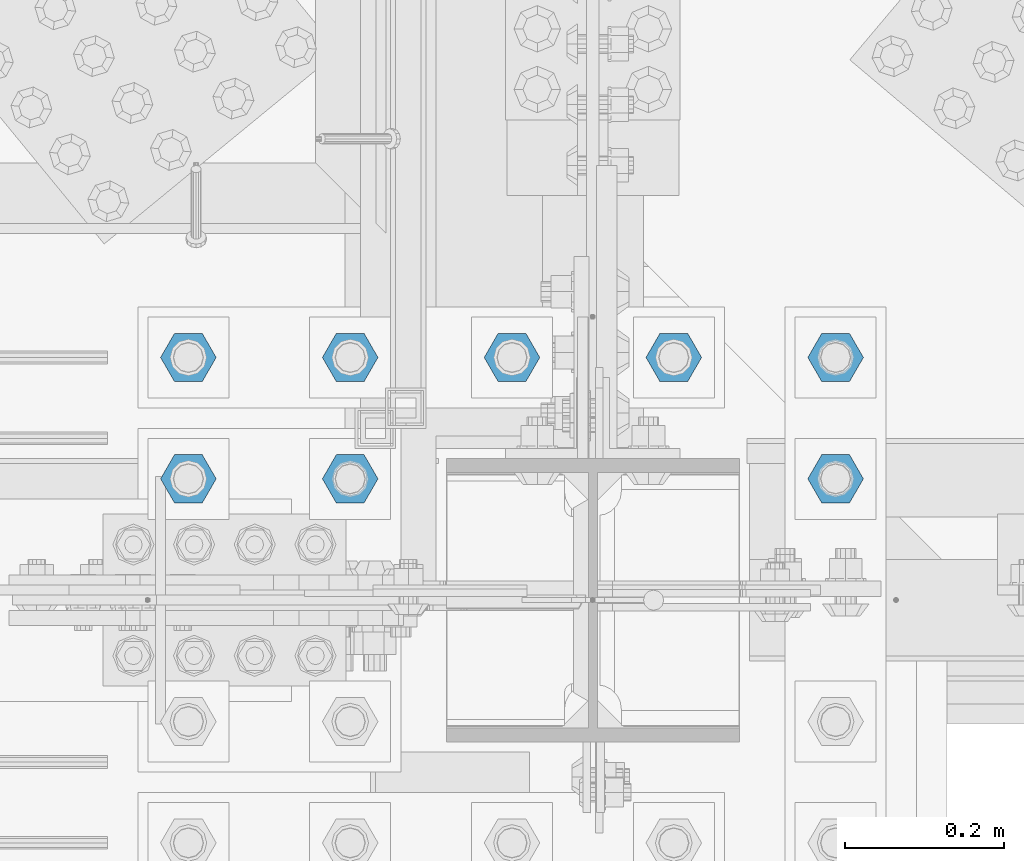
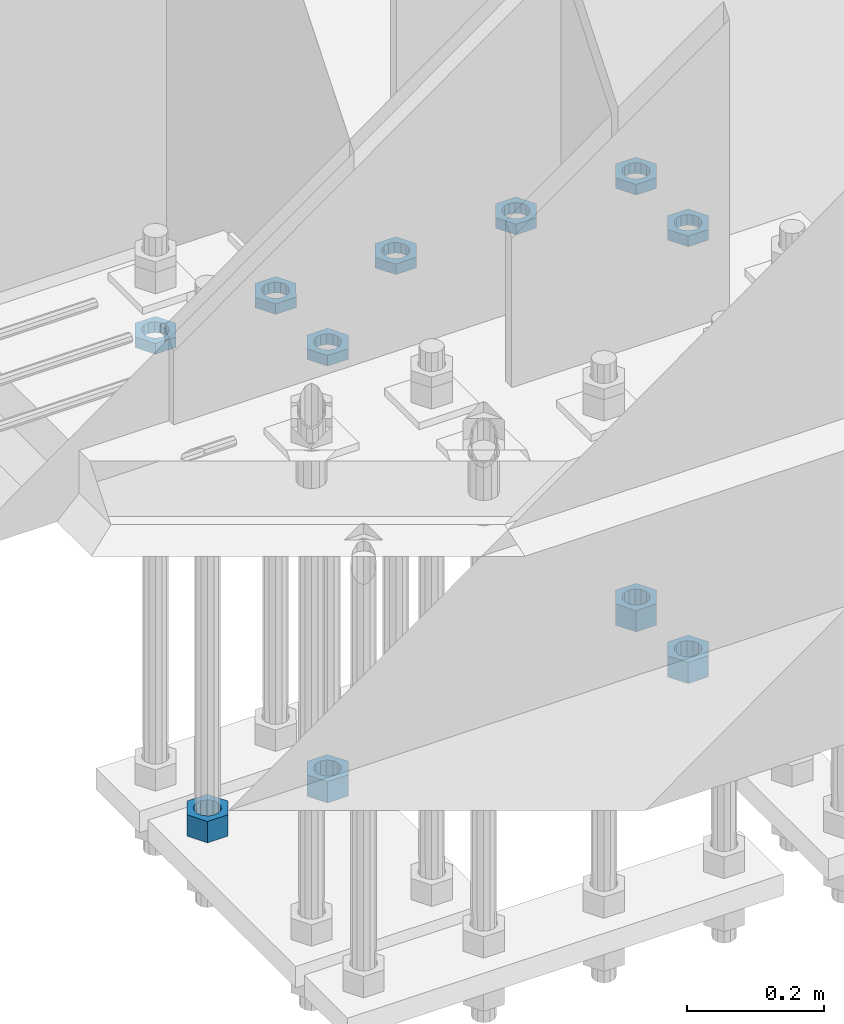
# One storey, part 2817 of 3843: 11 beams, 1 element without a shape of its own.
"""IFC2X3 building model written with IfcOpenShell, lengths in millimetres."""

import ifcopenshell
import ifcopenshell.guid

model = None  # the IFC model being written
_history = None  # IfcOwnerHistory: only IFC2X3 demands one
_inside = {}  # id of a spatial element -> (the spatial element, [elements in it])
_under = {}  # id of a project, library or spatial element -> (it, [spatial elements below it])
_declared = {}  # id of a project -> (the project, [libraries it declares])
_typed = {}  # id of a type object -> (the type object, [elements of that type])
_made_of = {}  # id of a material, layer set ... -> (it, [elements and type objects made of it])


def new_model(schema):
    """Start an empty IFC model of exactly this schema.

    Asked for "IFC4X3", IfcOpenShell would pick the latest addendum, in which some entities
    have other attributes; the version numbers below select the first issue.
    IFC2X3 requires an IfcOwnerHistory on every rooted entity: one is made here for all.
    """
    global model, _history
    if schema == "IFC4X3":
        model = ifcopenshell.file(schema_version=(4, 3, 0, 0))
    else:
        model = ifcopenshell.file(schema=schema)
    _inside.clear()
    _under.clear()
    _declared.clear()
    _typed.clear()
    _made_of.clear()
    _history = None
    if model.schema == "IFC2X3":
        org = make("IfcOrganization", Name="unknown")
        user = make(
            "IfcPersonAndOrganization",
            ThePerson=make("IfcPerson", FamilyName="unknown"),
            TheOrganization=org,
        )
        app = make(
            "IfcApplication",
            ApplicationDeveloper=org,
            Version="unknown",
            ApplicationFullName="unknown",
            ApplicationIdentifier="unknown",
        )
        _history = make(
            "IfcOwnerHistory",
            OwningUser=user,
            OwningApplication=app,
            ChangeAction="ADDED",
            CreationDate=0,
        )
    return model


def make(cls, **values):
    """One entity of the class cls with the attributes given. An attribute that is None is left unset."""
    return model.create_entity(
        cls, **{name: value for name, value in values.items() if value is not None}
    )


def rooted(cls, **values):
    """An entity with a GlobalId (a new one), such as an element, a storey or a relation."""
    return make(cls, GlobalId=ifcopenshell.guid.new(), OwnerHistory=_history, **values)


def si_unit(unit_type, name, prefix=None):
    """IfcSIUnit, for example si_unit("LENGTHUNIT", "METRE", prefix="MILLI")."""
    return make("IfcSIUnit", UnitType=unit_type, Prefix=prefix, Name=name)


def assignment(units):
    """IfcUnitAssignment: the units of a project."""
    return None if units is None else make("IfcUnitAssignment", Units=units)


def point(xyz):
    """IfcCartesianPoint."""
    return None if xyz is None else make("IfcCartesianPoint", Coordinates=xyz)


def direction(xyz):
    """IfcDirection."""
    return None if xyz is None else make("IfcDirection", DirectionRatios=xyz)


def frame(location, z_axis=None, x_axis=None):
    """IfcAxis2Placement3D, a coordinate frame: its origin and axes. An axis left out is left unset."""
    return make(
        "IfcAxis2Placement3D",
        Location=point(location),
        Axis=direction(z_axis),
        RefDirection=direction(x_axis),
    )


def origin_with_axes():
    """The frame at (0, 0, 0) with the z axis (0, 0, 1) and the x axis (1, 0, 0) written out."""
    return frame((0.0, 0.0, 0.0), z_axis=(0.0, 0.0, 1.0), x_axis=(1.0, 0.0, 0.0))


def place(relative_to, where):
    """IfcLocalPlacement: puts the frame where relative to a parent placement (None: the world)."""
    return make(
        "IfcLocalPlacement", PlacementRelTo=relative_to, RelativePlacement=where
    )


def context(
    kind, dimensions, precision=None, world=None, true_north=None, identifier=None
):
    """IfcGeometricRepresentationContext, for example the 3D "Model" context."""
    return make(
        "IfcGeometricRepresentationContext",
        ContextIdentifier=identifier,
        ContextType=kind,
        CoordinateSpaceDimension=dimensions,
        Precision=precision,
        WorldCoordinateSystem=world,
        TrueNorth=true_north,
    )


def subcontext(parent, identifier, kind, view, scale=None):
    """IfcGeometricRepresentationSubContext, for example "Body" below "Model"."""
    return make(
        "IfcGeometricRepresentationSubContext",
        ContextIdentifier=identifier,
        ContextType=kind,
        ParentContext=parent,
        TargetScale=scale,
        TargetView=view,
    )


def project(units=None, contexts=None):
    """IfcProject with its units and contexts."""
    return rooted(
        "IfcProject",
        Name="project",
        RepresentationContexts=contexts,
        UnitsInContext=assignment(units),
    )


def spatial(cls, under=None, at=None, **own):
    """A site, building, storey or space (cls), placed at a placement, below another one or the project."""
    s = rooted(cls, ObjectPlacement=at, **own)
    if under is not None:
        _under.setdefault(under.id(), (under, []))[1].append(s)
    return s


def faces_of(points, faces, orient=None, outer=None):
    """IfcFace entities. A face is a list of loops; a loop is a list of indices into points, from 0.

    orient and outer hold one flag for each loop. By default every Orientation is true, the
    first loop of a face is its IfcFaceOuterBound and the others are IfcFaceBound.
    """
    made = []
    for i, loops in enumerate(faces):
        bounds = []
        for j, loop in enumerate(loops):
            is_outer = j == 0 if outer is None else outer[i][j]
            bounds.append(
                make(
                    "IfcFaceOuterBound" if is_outer else "IfcFaceBound",
                    Bound=make("IfcPolyLoop", Polygon=[points[k] for k in loop]),
                    Orientation=True if orient is None else orient[i][j],
                )
            )
        made.append(make("IfcFace", Bounds=bounds))
    return made


def faceted_brep(points, faces, orient=None, outer=None, voids=None):
    """IfcFacetedBrep: a solid bounded by flat faces; with voids (closed shells), ...WithVoids."""
    shared = [point(p) for p in points]
    hull = make("IfcClosedShell", CfsFaces=faces_of(shared, faces, orient, outer))
    if voids is None:
        return make("IfcFacetedBrep", Outer=hull)
    return make(
        "IfcFacetedBrepWithVoids",
        Outer=hull,
        Voids=[
            make(cls, CfsFaces=faces_of(shared, fs, o, b)) for cls, fs, o, b in voids
        ],
    )


def shape(context_of_items, identifier, shape_type, items):
    """IfcShapeRepresentation: the items that make up one representation, for example the "Body"."""
    return make(
        "IfcShapeRepresentation",
        ContextOfItems=context_of_items,
        RepresentationIdentifier=identifier,
        RepresentationType=shape_type,
        Items=items,
    )


def material(Name=None, Category=None):
    """IfcMaterial."""
    return make("IfcMaterial", Name=Name, Category=Category)


def made_of(thing, what):
    """Note that an element or type object is made of a material, layer set ...; save() writes the relation."""
    if what is not None:
        _made_of.setdefault(what.id(), (what, []))[1].append(thing)
    return thing


def type_object(cls, material=None, **own):
    """A type object (cls), such as IfcWallType, which elements share."""
    return made_of(rooted(cls, **own), material)


def element(
    cls,
    number,
    at=None,
    inside=None,
    cuts=None,
    type_object=None,
    material=None,
    context=None,
    identifier="Body",
    shape_type=None,
    held_by="IfcProductDefinitionShape",
    body=None,
    shapes=None,
    **own,
):
    """One element of the class cls, such as IfcWall. Its Tag is "e" and its number.

    at: its placement. inside: the storey or other place that contains it. cuts: it is an
    opening in that element (IfcRelVoidsElement). A single representation is given by context,
    identifier, shape_type and body (its items); several are given by shapes. held_by: the class
    of the entity that holds the representations. save() writes the other relations.
    """
    e = rooted(cls, Tag="e%d" % number, ObjectPlacement=at, **own)
    if body is not None:
        shapes = [shape(context, identifier, shape_type, body)]
    if shapes is not None:
        e.Representation = make(held_by, Representations=shapes)
    if inside is not None:
        _inside.setdefault(inside.id(), (inside, []))[1].append(e)
    if cuts is not None:
        rooted(
            "IfcRelVoidsElement", RelatingBuildingElement=cuts, RelatedOpeningElement=e
        )
    if type_object is not None:
        _typed.setdefault(type_object.id(), (type_object, []))[1].append(e)
    return made_of(e, material)


def aggregate(whole, parts):
    """IfcRelAggregates: a whole, such as a stair, and the parts it consists of."""
    return rooted("IfcRelAggregates", RelatingObject=whole, RelatedObjects=parts)


def save(model, path):
    """Write the relations noted so far, then the file.

    IfcRelAggregates (storeys below a building ...), IfcRelContainedInSpatialStructure (elements
    in a storey), IfcRelDefinesByType, IfcRelAssociatesMaterial and IfcRelDeclares: one each for
    every whole, place, type object, material and project.
    """
    for whole, parts in _under.values():
        aggregate(whole, parts)
    for where, things in _inside.values():
        rooted(
            "IfcRelContainedInSpatialStructure",
            RelatedElements=things,
            RelatingStructure=where,
        )
    for kind, things in _typed.values():
        rooted("IfcRelDefinesByType", RelatedObjects=things, RelatingType=kind)
    for what, things in _made_of.values():
        rooted("IfcRelAssociatesMaterial", RelatedObjects=things, RelatingMaterial=what)
    for by, libraries in _declared.values():
        rooted("IfcRelDeclares", RelatingContext=by, RelatedDefinitions=libraries)
    model.write(path)


model = new_model("IFC2X3")

# Units and contexts
model_context = context("Model", 3, precision=1e-05, world=origin_with_axes())
body_context = subcontext(model_context, "Body", "Model", "MODEL_VIEW")
ifc_project = project(units=[si_unit("LENGTHUNIT", "METRE", prefix="MILLI"), si_unit("AREAUNIT", "SQUARE_METRE"), si_unit("VOLUMEUNIT", "CUBIC_METRE"), si_unit("MASSUNIT", "GRAM", prefix="KILO"), si_unit("TIMEUNIT", "SECOND"), si_unit("PLANEANGLEUNIT", "RADIAN"), si_unit("SOLIDANGLEUNIT", "STERADIAN"), si_unit("THERMODYNAMICTEMPERATUREUNIT", "DEGREE_CELSIUS"), si_unit("LUMINOUSINTENSITYUNIT", "LUMEN")], contexts=[model_context])

# Site, building, storey
site_placement = place(None, origin_with_axes())
site = spatial("IfcSite", under=ifc_project, at=site_placement, CompositionType="ELEMENT")
building_placement = place(site_placement, origin_with_axes())
building = spatial("IfcBuilding", under=site, at=building_placement, Name="Undefined", CompositionType="ELEMENT")
storey_placement = place(building_placement, origin_with_axes())
storey = spatial("IfcBuildingStorey", under=building, at=storey_placement, Name="Undefined", CompositionType="ELEMENT", Elevation=0.0)

# Assembly, beams
assembly_placement = place(storey_placement, origin_with_axes())
assembly = element("IfcElementAssembly", 1, at=assembly_placement, inside=storey, Name="TEMPLATE", AssemblyPlace="NOTDEFINED", PredefinedType="RIGID_FRAME")
ifc_material = material(Name="STEEL/A572-50")
beam_type_1 = type_object("IfcBeamType", Name="1-1/2_HEAVY_HEX_NUT", PredefinedType="NOTDEFINED")
beam_1_placement = place(assembly_placement, frame((48488.6, 25768.3, 28841.7000015259), z_axis=(0.0, 1.0, 0.0), x_axis=(0.0, 0.0, -1.0)))
beam_1 = element("IfcBeam", 2, at=beam_1_placement, type_object=beam_type_1, material=ifc_material, Name="NUT", ObjectType="1-1/2_HEAVY_HEX_NUT", context=body_context, shape_type="Brep", body=[
    faceted_brep([(0.0, -34.9199981689453, 0.0), (0.0, -17.4599990844727, -30.25), (38.0999999999985, -17.4599990844727, -30.25), (38.0999999999985, -34.9199981689453, 0.0), (0.0, 17.4599990844727, -30.25), (38.0999999999985, 17.4599990844727, -30.25), (0.0, 34.9199981689453, 0.0), (38.0999999999985, 34.9199981689453, 0.0), (0.0, 17.4599990844727, 30.25), (38.0999999999985, 17.4599990844727, 30.25), (0.0, -17.4599990844727, 30.25), (38.0999999999985, -17.4599990844727, 30.25), (0.0, 0.0, 20.6399993896484), (0.0, 8.9553601105581, 18.5959968835959), (38.0999999999985, 8.9553601105581, 18.5959968835959), (38.0999999999985, 0.0, 20.6399993896484), (0.0, 16.1370013209525, 12.8688291298167), (38.0999999999985, 16.1370013209525, 12.8688291298167), (0.0, 20.1225115123816, 4.59283194104501), (38.0999999999985, 20.1225115123816, 4.59283194104501), (0.0, 20.1225115123816, -4.59283194104501), (38.0999999999985, 20.1225115123816, -4.59283194104501), (0.0, 16.1370013209525, -12.8688291298167), (38.0999999999985, 16.1370013209525, -12.8688291298167), (0.0, 8.9553601105581, -18.5959968835959), (38.0999999999985, 8.9553601105581, -18.5959968835959), (0.0, 0.0, -20.6399993896484), (38.0999999999985, 0.0, -20.6399993896484), (0.0, -8.9553601105581, -18.5959968835959), (38.0999999999985, -8.9553601105581, -18.5959968835959), (0.0, -16.1370013209525, -12.8688291298167), (38.0999999999985, -16.1370013209525, -12.8688291298167), (0.0, -20.1225115123816, -4.59283194104501), (38.0999999999985, -20.1225115123816, -4.59283194104501), (0.0, -20.1225115123816, 4.59283194104501), (38.0999999999985, -20.1225115123816, 4.59283194104501), (0.0, -16.1370013209525, 12.8688291298167), (38.0999999999985, -16.1370013209525, 12.8688291298167), (0.0, -8.9553601105581, 18.5959968835959), (38.0999999999985, -8.9553601105581, 18.5959968835959)], [[[0, 1, 2, 3]], [[1, 4, 5, 2]], [[4, 6, 7, 5]], [[6, 8, 9, 7]], [[8, 10, 11, 9]], [[10, 0, 3, 11]], [[12, 13, 14, 15]], [[13, 16, 17, 14]], [[16, 18, 19, 17]], [[18, 20, 21, 19]], [[20, 22, 23, 21]], [[22, 24, 25, 23]], [[24, 26, 27, 25]], [[26, 28, 29, 27]], [[28, 30, 31, 29]], [[30, 32, 33, 31]], [[32, 34, 35, 33]], [[34, 36, 37, 35]], [[36, 38, 39, 37]], [[38, 12, 15, 39]], [[5, 7, 9, 11, 3, 2], [17, 19, 21, 23, 25, 27, 29, 31, 33, 35, 37, 39, 15, 14]], [[10, 8, 6, 4, 1, 0], [38, 36, 34, 32, 30, 28, 26, 24, 22, 20, 18, 16, 13, 12]]]),
])
beam_2_placement = place(assembly_placement, frame((48691.8, 25768.3, 28841.7000015259), z_axis=(0.0, 1.0, 0.0), x_axis=(0.0, 0.0, -1.0)))
beam_2 = element("IfcBeam", 3, at=beam_2_placement, type_object=beam_type_1, material=ifc_material, Name="NUT", ObjectType="1-1/2_HEAVY_HEX_NUT", context=body_context, shape_type="Brep", body=[
    faceted_brep([(0.0, -34.9199981689453, 0.0), (0.0, -17.4599990844727, -30.25), (38.0999999999985, -17.4599990844727, -30.25), (38.0999999999985, -34.9199981689453, 0.0), (0.0, 17.4599990844727, -30.25), (38.0999999999985, 17.4599990844727, -30.25), (0.0, 34.9199981689453, 0.0), (38.0999999999985, 34.9199981689453, 0.0), (0.0, 17.4599990844727, 30.25), (38.0999999999985, 17.4599990844727, 30.25), (0.0, -17.4599990844727, 30.25), (38.0999999999985, -17.4599990844727, 30.25), (0.0, 0.0, 20.6399993896484), (0.0, 8.9553601105581, 18.5959968835959), (38.0999999999985, 8.9553601105581, 18.5959968835959), (38.0999999999985, 0.0, 20.6399993896484), (0.0, 16.1370013209525, 12.8688291298167), (38.0999999999985, 16.1370013209525, 12.8688291298167), (0.0, 20.1225115123816, 4.59283194104501), (38.0999999999985, 20.1225115123816, 4.59283194104501), (0.0, 20.1225115123816, -4.59283194104501), (38.0999999999985, 20.1225115123816, -4.59283194104501), (0.0, 16.1370013209525, -12.8688291298167), (38.0999999999985, 16.1370013209525, -12.8688291298167), (0.0, 8.9553601105581, -18.5959968835959), (38.0999999999985, 8.9553601105581, -18.5959968835959), (0.0, 0.0, -20.6399993896484), (38.0999999999985, 0.0, -20.6399993896484), (0.0, -8.9553601105581, -18.5959968835959), (38.0999999999985, -8.9553601105581, -18.5959968835959), (0.0, -16.1370013209525, -12.8688291298167), (38.0999999999985, -16.1370013209525, -12.8688291298167), (0.0, -20.1225115123816, -4.59283194104501), (38.0999999999985, -20.1225115123816, -4.59283194104501), (0.0, -20.1225115123816, 4.59283194104501), (38.0999999999985, -20.1225115123816, 4.59283194104501), (0.0, -16.1370013209525, 12.8688291298167), (38.0999999999985, -16.1370013209525, 12.8688291298167), (0.0, -8.9553601105581, 18.5959968835959), (38.0999999999985, -8.9553601105581, 18.5959968835959)], [[[0, 1, 2, 3]], [[1, 4, 5, 2]], [[4, 6, 7, 5]], [[6, 8, 9, 7]], [[8, 10, 11, 9]], [[10, 0, 3, 11]], [[12, 13, 14, 15]], [[13, 16, 17, 14]], [[16, 18, 19, 17]], [[18, 20, 21, 19]], [[20, 22, 23, 21]], [[22, 24, 25, 23]], [[24, 26, 27, 25]], [[26, 28, 29, 27]], [[28, 30, 31, 29]], [[30, 32, 33, 31]], [[32, 34, 35, 33]], [[34, 36, 37, 35]], [[36, 38, 39, 37]], [[38, 12, 15, 39]], [[5, 7, 9, 11, 3, 2], [17, 19, 21, 23, 25, 27, 29, 31, 33, 35, 37, 39, 15, 14]], [[10, 8, 6, 4, 1, 0], [38, 36, 34, 32, 30, 28, 26, 24, 22, 20, 18, 16, 13, 12]]]),
])
beam_3_placement = place(assembly_placement, frame((49301.4, 25920.7, 28841.7000015259), z_axis=(0.0, -1.0, 0.0), x_axis=(0.0, 0.0, -1.0)))
beam_3 = element("IfcBeam", 4, at=beam_3_placement, type_object=beam_type_1, material=ifc_material, Name="NUT", ObjectType="1-1/2_HEAVY_HEX_NUT", context=body_context, shape_type="Brep", body=[
    faceted_brep([(0.0, -34.9199981689453, 0.0), (0.0, -17.4599990844727, -30.25), (38.0999999999985, -17.4599990844727, -30.25), (38.0999999999985, -34.9199981689453, 0.0), (0.0, 17.4599990844727, -30.25), (38.0999999999985, 17.4599990844727, -30.25), (0.0, 34.9199981689453, 0.0), (38.0999999999985, 34.9199981689453, 0.0), (0.0, 17.4599990844727, 30.25), (38.0999999999985, 17.4599990844727, 30.25), (0.0, -17.4599990844727, 30.25), (38.0999999999985, -17.4599990844727, 30.25), (0.0, 0.0, 20.6399993896484), (0.0, 8.9553601105581, 18.5959968835959), (38.0999999999985, 8.9553601105581, 18.5959968835959), (38.0999999999985, 0.0, 20.6399993896484), (0.0, 16.1370013209525, 12.8688291298167), (38.0999999999985, 16.1370013209525, 12.8688291298167), (0.0, 20.1225115123816, 4.59283194104501), (38.0999999999985, 20.1225115123816, 4.59283194104501), (0.0, 20.1225115123816, -4.59283194104501), (38.0999999999985, 20.1225115123816, -4.59283194104501), (0.0, 16.1370013209525, -12.8688291298167), (38.0999999999985, 16.1370013209525, -12.8688291298167), (0.0, 8.9553601105581, -18.5959968835959), (38.0999999999985, 8.9553601105581, -18.5959968835959), (0.0, 0.0, -20.6399993896484), (38.0999999999985, 0.0, -20.6399993896484), (0.0, -8.9553601105581, -18.5959968835959), (38.0999999999985, -8.9553601105581, -18.5959968835959), (0.0, -16.1370013209525, -12.8688291298167), (38.0999999999985, -16.1370013209525, -12.8688291298167), (0.0, -20.1225115123816, -4.59283194104501), (38.0999999999985, -20.1225115123816, -4.59283194104501), (0.0, -20.1225115123816, 4.59283194104501), (38.0999999999985, -20.1225115123816, 4.59283194104501), (0.0, -16.1370013209525, 12.8688291298167), (38.0999999999985, -16.1370013209525, 12.8688291298167), (0.0, -8.9553601105581, 18.5959968835959), (38.0999999999985, -8.9553601105581, 18.5959968835959)], [[[0, 1, 2, 3]], [[1, 4, 5, 2]], [[4, 6, 7, 5]], [[6, 8, 9, 7]], [[8, 10, 11, 9]], [[10, 0, 3, 11]], [[12, 13, 14, 15]], [[13, 16, 17, 14]], [[16, 18, 19, 17]], [[18, 20, 21, 19]], [[20, 22, 23, 21]], [[22, 24, 25, 23]], [[24, 26, 27, 25]], [[26, 28, 29, 27]], [[28, 30, 31, 29]], [[30, 32, 33, 31]], [[32, 34, 35, 33]], [[34, 36, 37, 35]], [[36, 38, 39, 37]], [[38, 12, 15, 39]], [[5, 7, 9, 11, 3, 2], [17, 19, 21, 23, 25, 27, 29, 31, 33, 35, 37, 39, 15, 14]], [[10, 8, 6, 4, 1, 0], [38, 36, 34, 32, 30, 28, 26, 24, 22, 20, 18, 16, 13, 12]]]),
])
beam_4_placement = place(assembly_placement, frame((49301.4, 25768.3, 28841.7000015259), z_axis=(0.0, -1.0, 0.0), x_axis=(0.0, 0.0, -1.0)))
beam_4 = element("IfcBeam", 5, at=beam_4_placement, type_object=beam_type_1, material=ifc_material, Name="NUT", ObjectType="1-1/2_HEAVY_HEX_NUT", context=body_context, shape_type="Brep", body=[
    faceted_brep([(0.0, -34.9199981689453, 0.0), (0.0, -17.4599990844727, -30.25), (38.0999999999985, -17.4599990844727, -30.25), (38.0999999999985, -34.9199981689453, 0.0), (0.0, 17.4599990844727, -30.25), (38.0999999999985, 17.4599990844727, -30.25), (0.0, 34.9199981689453, 0.0), (38.0999999999985, 34.9199981689453, 0.0), (0.0, 17.4599990844727, 30.25), (38.0999999999985, 17.4599990844727, 30.25), (0.0, -17.4599990844727, 30.25), (38.0999999999985, -17.4599990844727, 30.25), (0.0, 0.0, 20.6399993896484), (0.0, 8.9553601105581, 18.5959968835959), (38.0999999999985, 8.9553601105581, 18.5959968835959), (38.0999999999985, 0.0, 20.6399993896484), (0.0, 16.1370013209525, 12.8688291298167), (38.0999999999985, 16.1370013209525, 12.8688291298167), (0.0, 20.1225115123816, 4.59283194104501), (38.0999999999985, 20.1225115123816, 4.59283194104501), (0.0, 20.1225115123816, -4.59283194104501), (38.0999999999985, 20.1225115123816, -4.59283194104501), (0.0, 16.1370013209525, -12.8688291298167), (38.0999999999985, 16.1370013209525, -12.8688291298167), (0.0, 8.9553601105581, -18.5959968835959), (38.0999999999985, 8.9553601105581, -18.5959968835959), (0.0, 0.0, -20.6399993896484), (38.0999999999985, 0.0, -20.6399993896484), (0.0, -8.9553601105581, -18.5959968835959), (38.0999999999985, -8.9553601105581, -18.5959968835959), (0.0, -16.1370013209525, -12.8688291298167), (38.0999999999985, -16.1370013209525, -12.8688291298167), (0.0, -20.1225115123816, -4.59283194104501), (38.0999999999985, -20.1225115123816, -4.59283194104501), (0.0, -20.1225115123816, 4.59283194104501), (38.0999999999985, -20.1225115123816, 4.59283194104501), (0.0, -16.1370013209525, 12.8688291298167), (38.0999999999985, -16.1370013209525, 12.8688291298167), (0.0, -8.9553601105581, 18.5959968835959), (38.0999999999985, -8.9553601105581, 18.5959968835959)], [[[0, 1, 2, 3]], [[1, 4, 5, 2]], [[4, 6, 7, 5]], [[6, 8, 9, 7]], [[8, 10, 11, 9]], [[10, 0, 3, 11]], [[12, 13, 14, 15]], [[13, 16, 17, 14]], [[16, 18, 19, 17]], [[18, 20, 21, 19]], [[20, 22, 23, 21]], [[22, 24, 25, 23]], [[24, 26, 27, 25]], [[26, 28, 29, 27]], [[28, 30, 31, 29]], [[30, 32, 33, 31]], [[32, 34, 35, 33]], [[34, 36, 37, 35]], [[36, 38, 39, 37]], [[38, 12, 15, 39]], [[5, 7, 9, 11, 3, 2], [17, 19, 21, 23, 25, 27, 29, 31, 33, 35, 37, 39, 15, 14]], [[10, 8, 6, 4, 1, 0], [38, 36, 34, 32, 30, 28, 26, 24, 22, 20, 18, 16, 13, 12]]]),
])
beam_type_2 = type_object("IfcBeamType", Name="1-1/2_HALF_NUT", PredefinedType="NOTDEFINED")
beam_5_placement = place(assembly_placement, frame((49098.2, 25920.7, 29603.7), z_axis=(0.0, 1.0, 0.0), x_axis=(0.0, 0.0, -1.0)))
beam_5 = element("IfcBeam", 6, at=beam_5_placement, type_object=beam_type_2, material=ifc_material, Name="NUT", ObjectType="1-1/2_HALF_NUT", context=body_context, shape_type="Brep", body=[
    faceted_brep([(0.0, -34.9199981689453, 0.0), (0.0, -17.4599990844727, -30.25), (19.0500000000029, -17.4599990844727, -30.25), (19.0500000000029, -34.9199981689453, 0.0), (0.0, 17.4599990844727, -30.25), (19.0500000000029, 17.4599990844727, -30.25), (0.0, 34.9199981689453, 0.0), (19.0500000000029, 34.9199981689453, 0.0), (0.0, 17.4599990844727, 30.25), (19.0500000000029, 17.4599990844727, 30.25), (0.0, -17.4599990844727, 30.25), (19.0500000000029, -17.4599990844727, 30.25), (0.0, 0.0, 20.6399993896484), (0.0, 8.9553601105581, 18.5959968835959), (19.0500000000029, 8.95536011056538, 18.5959968835959), (19.0500000000029, 0.0, 20.6399993896484), (0.0, 16.1370013209525, 12.8688291298167), (19.0500000000029, 16.1370013209489, 12.8688291298167), (0.0, 20.1225115123816, 4.59283194104501), (19.0500000000029, 20.1225115123852, 4.59283194104501), (0.0, 20.1225115123816, -4.59283194104501), (19.0500000000029, 20.1225115123852, -4.59283194104501), (0.0, 16.1370013209525, -12.8688291298167), (19.0500000000029, 16.1370013209489, -12.8688291298167), (0.0, 8.9553601105581, -18.5959968835959), (19.0500000000029, 8.95536011056538, -18.5959968835959), (0.0, 0.0, -20.6399993896484), (19.0500000000029, 0.0, -20.6399993896484), (0.0, -8.9553601105581, -18.5959968835959), (19.0500000000029, -8.95536011056538, -18.5959968835959), (0.0, -16.1370013209525, -12.8688291298167), (19.0500000000029, -16.1370013209489, -12.8688291298167), (0.0, -20.1225115123816, -4.59283194104501), (19.0500000000029, -20.1225115123852, -4.59283194104501), (0.0, -20.1225115123816, 4.59283194104501), (19.0500000000029, -20.1225115123852, 4.59283194104501), (0.0, -16.1370013209525, 12.8688291298167), (19.0500000000029, -16.1370013209489, 12.8688291298167), (0.0, -8.9553601105581, 18.5959968835959), (19.0500000000029, -8.95536011056538, 18.5959968835959)], [[[0, 1, 2, 3]], [[1, 4, 5, 2]], [[4, 6, 7, 5]], [[6, 8, 9, 7]], [[8, 10, 11, 9]], [[10, 0, 3, 11]], [[12, 13, 14, 15]], [[13, 16, 17, 14]], [[16, 18, 19, 17]], [[18, 20, 21, 19]], [[20, 22, 23, 21]], [[22, 24, 25, 23]], [[24, 26, 27, 25]], [[26, 28, 29, 27]], [[28, 30, 31, 29]], [[30, 32, 33, 31]], [[32, 34, 35, 33]], [[34, 36, 37, 35]], [[36, 38, 39, 37]], [[38, 12, 15, 39]], [[5, 7, 9, 11, 3, 2], [17, 19, 21, 23, 25, 27, 29, 31, 33, 35, 37, 39, 15, 14]], [[10, 8, 6, 4, 1, 0], [38, 36, 34, 32, 30, 28, 26, 24, 22, 20, 18, 16, 13, 12]]]),
])
beam_6_placement = place(assembly_placement, frame((49301.4, 25920.7, 29603.7), z_axis=(0.0, 1.0, 0.0), x_axis=(0.0, 0.0, -1.0)))
beam_6 = element("IfcBeam", 7, at=beam_6_placement, type_object=beam_type_2, material=ifc_material, Name="NUT", ObjectType="1-1/2_HALF_NUT", context=body_context, shape_type="Brep", body=[
    faceted_brep([(0.0, -34.9199981689453, 0.0), (0.0, -17.4599990844727, -30.25), (19.0500000000029, -17.4599990844727, -30.25), (19.0500000000029, -34.9199981689453, 0.0), (0.0, 17.4599990844727, -30.25), (19.0500000000029, 17.4599990844727, -30.25), (0.0, 34.9199981689453, 0.0), (19.0500000000029, 34.9199981689453, 0.0), (0.0, 17.4599990844727, 30.25), (19.0500000000029, 17.4599990844727, 30.25), (0.0, -17.4599990844727, 30.25), (19.0500000000029, -17.4599990844727, 30.25), (0.0, 0.0, 20.6399993896484), (0.0, 8.9553601105581, 18.5959968835959), (19.0500000000029, 8.95536011056538, 18.5959968835959), (19.0500000000029, 0.0, 20.6399993896484), (0.0, 16.1370013209525, 12.8688291298167), (19.0500000000029, 16.1370013209489, 12.8688291298167), (0.0, 20.1225115123816, 4.59283194104501), (19.0500000000029, 20.1225115123852, 4.59283194104501), (0.0, 20.1225115123816, -4.59283194104501), (19.0500000000029, 20.1225115123852, -4.59283194104501), (0.0, 16.1370013209525, -12.8688291298167), (19.0500000000029, 16.1370013209489, -12.8688291298167), (0.0, 8.9553601105581, -18.5959968835959), (19.0500000000029, 8.95536011056538, -18.5959968835959), (0.0, 0.0, -20.6399993896484), (19.0500000000029, 0.0, -20.6399993896484), (0.0, -8.9553601105581, -18.5959968835959), (19.0500000000029, -8.95536011056538, -18.5959968835959), (0.0, -16.1370013209525, -12.8688291298167), (19.0500000000029, -16.1370013209489, -12.8688291298167), (0.0, -20.1225115123816, -4.59283194104501), (19.0500000000029, -20.1225115123852, -4.59283194104501), (0.0, -20.1225115123816, 4.59283194104501), (19.0500000000029, -20.1225115123852, 4.59283194104501), (0.0, -16.1370013209525, 12.8688291298167), (19.0500000000029, -16.1370013209489, 12.8688291298167), (0.0, -8.9553601105581, 18.5959968835959), (19.0500000000029, -8.95536011056538, 18.5959968835959)], [[[0, 1, 2, 3]], [[1, 4, 5, 2]], [[4, 6, 7, 5]], [[6, 8, 9, 7]], [[8, 10, 11, 9]], [[10, 0, 3, 11]], [[12, 13, 14, 15]], [[13, 16, 17, 14]], [[16, 18, 19, 17]], [[18, 20, 21, 19]], [[20, 22, 23, 21]], [[22, 24, 25, 23]], [[24, 26, 27, 25]], [[26, 28, 29, 27]], [[28, 30, 31, 29]], [[30, 32, 33, 31]], [[32, 34, 35, 33]], [[34, 36, 37, 35]], [[36, 38, 39, 37]], [[38, 12, 15, 39]], [[5, 7, 9, 11, 3, 2], [17, 19, 21, 23, 25, 27, 29, 31, 33, 35, 37, 39, 15, 14]], [[10, 8, 6, 4, 1, 0], [38, 36, 34, 32, 30, 28, 26, 24, 22, 20, 18, 16, 13, 12]]]),
])
beam_7_placement = place(assembly_placement, frame((49301.4, 25768.3, 29603.7), z_axis=(0.0, 1.0, 0.0), x_axis=(0.0, 0.0, -1.0)))
beam_7 = element("IfcBeam", 8, at=beam_7_placement, type_object=beam_type_2, material=ifc_material, Name="NUT", ObjectType="1-1/2_HALF_NUT", context=body_context, shape_type="Brep", body=[
    faceted_brep([(0.0, -34.9199981689453, 0.0), (0.0, -17.4599990844727, -30.25), (19.0500000000029, -17.4599990844727, -30.25), (19.0500000000029, -34.9199981689453, 0.0), (0.0, 17.4599990844727, -30.25), (19.0500000000029, 17.4599990844727, -30.25), (0.0, 34.9199981689453, 0.0), (19.0500000000029, 34.9199981689453, 0.0), (0.0, 17.4599990844727, 30.25), (19.0500000000029, 17.4599990844727, 30.25), (0.0, -17.4599990844727, 30.25), (19.0500000000029, -17.4599990844727, 30.25), (0.0, 0.0, 20.6399993896484), (0.0, 8.9553601105581, 18.5959968835959), (19.0500000000029, 8.95536011056538, 18.5959968835959), (19.0500000000029, 0.0, 20.6399993896484), (0.0, 16.1370013209525, 12.8688291298167), (19.0500000000029, 16.1370013209489, 12.8688291298167), (0.0, 20.1225115123816, 4.59283194104501), (19.0500000000029, 20.1225115123852, 4.59283194104501), (0.0, 20.1225115123816, -4.59283194104501), (19.0500000000029, 20.1225115123852, -4.59283194104501), (0.0, 16.1370013209525, -12.8688291298167), (19.0500000000029, 16.1370013209489, -12.8688291298167), (0.0, 8.9553601105581, -18.5959968835959), (19.0500000000029, 8.95536011056538, -18.5959968835959), (0.0, 0.0, -20.6399993896484), (19.0500000000029, 0.0, -20.6399993896484), (0.0, -8.9553601105581, -18.5959968835959), (19.0500000000029, -8.95536011056538, -18.5959968835959), (0.0, -16.1370013209525, -12.8688291298167), (19.0500000000029, -16.1370013209489, -12.8688291298167), (0.0, -20.1225115123816, -4.59283194104501), (19.0500000000029, -20.1225115123852, -4.59283194104501), (0.0, -20.1225115123816, 4.59283194104501), (19.0500000000029, -20.1225115123852, 4.59283194104501), (0.0, -16.1370013209525, 12.8688291298167), (19.0500000000029, -16.1370013209489, 12.8688291298167), (0.0, -8.9553601105581, 18.5959968835959), (19.0500000000029, -8.95536011056538, 18.5959968835959)], [[[0, 1, 2, 3]], [[1, 4, 5, 2]], [[4, 6, 7, 5]], [[6, 8, 9, 7]], [[8, 10, 11, 9]], [[10, 0, 3, 11]], [[12, 13, 14, 15]], [[13, 16, 17, 14]], [[16, 18, 19, 17]], [[18, 20, 21, 19]], [[20, 22, 23, 21]], [[22, 24, 25, 23]], [[24, 26, 27, 25]], [[26, 28, 29, 27]], [[28, 30, 31, 29]], [[30, 32, 33, 31]], [[32, 34, 35, 33]], [[34, 36, 37, 35]], [[36, 38, 39, 37]], [[38, 12, 15, 39]], [[5, 7, 9, 11, 3, 2], [17, 19, 21, 23, 25, 27, 29, 31, 33, 35, 37, 39, 15, 14]], [[10, 8, 6, 4, 1, 0], [38, 36, 34, 32, 30, 28, 26, 24, 22, 20, 18, 16, 13, 12]]]),
])
beam_8_placement = place(assembly_placement, frame((48895.0, 25920.7, 29603.7), z_axis=(0.0, -1.0, 0.0), x_axis=(0.0, 0.0, -1.0)))
beam_8 = element("IfcBeam", 9, at=beam_8_placement, type_object=beam_type_2, material=ifc_material, Name="NUT", ObjectType="1-1/2_HALF_NUT", context=body_context, shape_type="Brep", body=[
    faceted_brep([(0.0, -34.9199981689453, 0.0), (0.0, -17.4599990844727, -30.25), (19.0500000000029, -17.4599990844727, -30.25), (19.0500000000029, -34.9199981689453, 0.0), (0.0, 17.4599990844727, -30.25), (19.0500000000029, 17.4599990844727, -30.25), (0.0, 34.9199981689453, 0.0), (19.0500000000029, 34.9199981689453, 0.0), (0.0, 17.4599990844727, 30.25), (19.0500000000029, 17.4599990844727, 30.25), (0.0, -17.4599990844727, 30.25), (19.0500000000029, -17.4599990844727, 30.25), (0.0, 0.0, 20.6399993896484), (0.0, 8.9553601105581, 18.5959968835959), (19.0500000000029, 8.95536011056538, 18.5959968835959), (19.0500000000029, 0.0, 20.6399993896484), (0.0, 16.1370013209525, 12.8688291298167), (19.0500000000029, 16.1370013209489, 12.8688291298167), (0.0, 20.1225115123816, 4.59283194104501), (19.0500000000029, 20.1225115123852, 4.59283194104501), (0.0, 20.1225115123816, -4.59283194104501), (19.0500000000029, 20.1225115123852, -4.59283194104501), (0.0, 16.1370013209525, -12.8688291298167), (19.0500000000029, 16.1370013209489, -12.8688291298167), (0.0, 8.9553601105581, -18.5959968835959), (19.0500000000029, 8.95536011056538, -18.5959968835959), (0.0, 0.0, -20.6399993896484), (19.0500000000029, 0.0, -20.6399993896484), (0.0, -8.9553601105581, -18.5959968835959), (19.0500000000029, -8.95536011056538, -18.5959968835959), (0.0, -16.1370013209525, -12.8688291298167), (19.0500000000029, -16.1370013209489, -12.8688291298167), (0.0, -20.1225115123816, -4.59283194104501), (19.0500000000029, -20.1225115123852, -4.59283194104501), (0.0, -20.1225115123816, 4.59283194104501), (19.0500000000029, -20.1225115123852, 4.59283194104501), (0.0, -16.1370013209525, 12.8688291298167), (19.0500000000029, -16.1370013209489, 12.8688291298167), (0.0, -8.9553601105581, 18.5959968835959), (19.0500000000029, -8.95536011056538, 18.5959968835959)], [[[0, 1, 2, 3]], [[1, 4, 5, 2]], [[4, 6, 7, 5]], [[6, 8, 9, 7]], [[8, 10, 11, 9]], [[10, 0, 3, 11]], [[12, 13, 14, 15]], [[13, 16, 17, 14]], [[16, 18, 19, 17]], [[18, 20, 21, 19]], [[20, 22, 23, 21]], [[22, 24, 25, 23]], [[24, 26, 27, 25]], [[26, 28, 29, 27]], [[28, 30, 31, 29]], [[30, 32, 33, 31]], [[32, 34, 35, 33]], [[34, 36, 37, 35]], [[36, 38, 39, 37]], [[38, 12, 15, 39]], [[5, 7, 9, 11, 3, 2], [17, 19, 21, 23, 25, 27, 29, 31, 33, 35, 37, 39, 15, 14]], [[10, 8, 6, 4, 1, 0], [38, 36, 34, 32, 30, 28, 26, 24, 22, 20, 18, 16, 13, 12]]]),
])
beam_9_placement = place(assembly_placement, frame((48691.8, 25920.7, 29603.7), z_axis=(0.0, -1.0, 0.0), x_axis=(0.0, 0.0, -1.0)))
beam_9 = element("IfcBeam", 10, at=beam_9_placement, type_object=beam_type_2, material=ifc_material, Name="NUT", ObjectType="1-1/2_HALF_NUT", context=body_context, shape_type="Brep", body=[
    faceted_brep([(0.0, -34.9199981689453, 0.0), (0.0, -17.4599990844727, -30.25), (19.0500000000029, -17.4599990844727, -30.25), (19.0500000000029, -34.9199981689453, 0.0), (0.0, 17.4599990844727, -30.25), (19.0500000000029, 17.4599990844727, -30.25), (0.0, 34.9199981689453, 0.0), (19.0500000000029, 34.9199981689453, 0.0), (0.0, 17.4599990844727, 30.25), (19.0500000000029, 17.4599990844727, 30.25), (0.0, -17.4599990844727, 30.25), (19.0500000000029, -17.4599990844727, 30.25), (0.0, 0.0, 20.6399993896484), (0.0, 8.9553601105581, 18.5959968835959), (19.0500000000029, 8.95536011056538, 18.5959968835959), (19.0500000000029, 0.0, 20.6399993896484), (0.0, 16.1370013209525, 12.8688291298167), (19.0500000000029, 16.1370013209489, 12.8688291298167), (0.0, 20.1225115123816, 4.59283194104501), (19.0500000000029, 20.1225115123852, 4.59283194104501), (0.0, 20.1225115123816, -4.59283194104501), (19.0500000000029, 20.1225115123852, -4.59283194104501), (0.0, 16.1370013209525, -12.8688291298167), (19.0500000000029, 16.1370013209489, -12.8688291298167), (0.0, 8.9553601105581, -18.5959968835959), (19.0500000000029, 8.95536011056538, -18.5959968835959), (0.0, 0.0, -20.6399993896484), (19.0500000000029, 0.0, -20.6399993896484), (0.0, -8.9553601105581, -18.5959968835959), (19.0500000000029, -8.95536011056538, -18.5959968835959), (0.0, -16.1370013209525, -12.8688291298167), (19.0500000000029, -16.1370013209489, -12.8688291298167), (0.0, -20.1225115123816, -4.59283194104501), (19.0500000000029, -20.1225115123852, -4.59283194104501), (0.0, -20.1225115123816, 4.59283194104501), (19.0500000000029, -20.1225115123852, 4.59283194104501), (0.0, -16.1370013209525, 12.8688291298167), (19.0500000000029, -16.1370013209489, 12.8688291298167), (0.0, -8.9553601105581, 18.5959968835959), (19.0500000000029, -8.95536011056538, 18.5959968835959)], [[[0, 1, 2, 3]], [[1, 4, 5, 2]], [[4, 6, 7, 5]], [[6, 8, 9, 7]], [[8, 10, 11, 9]], [[10, 0, 3, 11]], [[12, 13, 14, 15]], [[13, 16, 17, 14]], [[16, 18, 19, 17]], [[18, 20, 21, 19]], [[20, 22, 23, 21]], [[22, 24, 25, 23]], [[24, 26, 27, 25]], [[26, 28, 29, 27]], [[28, 30, 31, 29]], [[30, 32, 33, 31]], [[32, 34, 35, 33]], [[34, 36, 37, 35]], [[36, 38, 39, 37]], [[38, 12, 15, 39]], [[5, 7, 9, 11, 3, 2], [17, 19, 21, 23, 25, 27, 29, 31, 33, 35, 37, 39, 15, 14]], [[10, 8, 6, 4, 1, 0], [38, 36, 34, 32, 30, 28, 26, 24, 22, 20, 18, 16, 13, 12]]]),
])
beam_10_placement = place(assembly_placement, frame((48691.8, 25768.3, 29603.7), z_axis=(0.0, -1.0, 0.0), x_axis=(0.0, 0.0, -1.0)))
beam_10 = element("IfcBeam", 11, at=beam_10_placement, type_object=beam_type_2, material=ifc_material, Name="NUT", ObjectType="1-1/2_HALF_NUT", context=body_context, shape_type="Brep", body=[
    faceted_brep([(0.0, -34.9199981689453, 0.0), (0.0, -17.4599990844727, -30.25), (19.0500000000029, -17.4599990844727, -30.25), (19.0500000000029, -34.9199981689453, 0.0), (0.0, 17.4599990844727, -30.25), (19.0500000000029, 17.4599990844727, -30.25), (0.0, 34.9199981689453, 0.0), (19.0500000000029, 34.9199981689453, 0.0), (0.0, 17.4599990844727, 30.25), (19.0500000000029, 17.4599990844727, 30.25), (0.0, -17.4599990844727, 30.25), (19.0500000000029, -17.4599990844727, 30.25), (0.0, 0.0, 20.6399993896484), (0.0, 8.9553601105581, 18.5959968835959), (19.0500000000029, 8.95536011056538, 18.5959968835959), (19.0500000000029, 0.0, 20.6399993896484), (0.0, 16.1370013209525, 12.8688291298167), (19.0500000000029, 16.1370013209489, 12.8688291298167), (0.0, 20.1225115123816, 4.59283194104501), (19.0500000000029, 20.1225115123852, 4.59283194104501), (0.0, 20.1225115123816, -4.59283194104501), (19.0500000000029, 20.1225115123852, -4.59283194104501), (0.0, 16.1370013209525, -12.8688291298167), (19.0500000000029, 16.1370013209489, -12.8688291298167), (0.0, 8.9553601105581, -18.5959968835959), (19.0500000000029, 8.95536011056538, -18.5959968835959), (0.0, 0.0, -20.6399993896484), (19.0500000000029, 0.0, -20.6399993896484), (0.0, -8.9553601105581, -18.5959968835959), (19.0500000000029, -8.95536011056538, -18.5959968835959), (0.0, -16.1370013209525, -12.8688291298167), (19.0500000000029, -16.1370013209489, -12.8688291298167), (0.0, -20.1225115123816, -4.59283194104501), (19.0500000000029, -20.1225115123852, -4.59283194104501), (0.0, -20.1225115123816, 4.59283194104501), (19.0500000000029, -20.1225115123852, 4.59283194104501), (0.0, -16.1370013209525, 12.8688291298167), (19.0500000000029, -16.1370013209489, 12.8688291298167), (0.0, -8.9553601105581, 18.5959968835959), (19.0500000000029, -8.95536011056538, 18.5959968835959)], [[[0, 1, 2, 3]], [[1, 4, 5, 2]], [[4, 6, 7, 5]], [[6, 8, 9, 7]], [[8, 10, 11, 9]], [[10, 0, 3, 11]], [[12, 13, 14, 15]], [[13, 16, 17, 14]], [[16, 18, 19, 17]], [[18, 20, 21, 19]], [[20, 22, 23, 21]], [[22, 24, 25, 23]], [[24, 26, 27, 25]], [[26, 28, 29, 27]], [[28, 30, 31, 29]], [[30, 32, 33, 31]], [[32, 34, 35, 33]], [[34, 36, 37, 35]], [[36, 38, 39, 37]], [[38, 12, 15, 39]], [[5, 7, 9, 11, 3, 2], [17, 19, 21, 23, 25, 27, 29, 31, 33, 35, 37, 39, 15, 14]], [[10, 8, 6, 4, 1, 0], [38, 36, 34, 32, 30, 28, 26, 24, 22, 20, 18, 16, 13, 12]]]),
])
beam_11_placement = place(assembly_placement, frame((48488.6, 25920.7, 29603.7), z_axis=(0.0, -1.0, 0.0), x_axis=(0.0, 0.0, -1.0)))
beam_11 = element("IfcBeam", 12, at=beam_11_placement, type_object=beam_type_2, material=ifc_material, Name="NUT", ObjectType="1-1/2_HALF_NUT", context=body_context, shape_type="Brep", body=[
    faceted_brep([(0.0, -34.9199981689453, 0.0), (0.0, -17.4599990844727, -30.25), (19.0500000000029, -17.4599990844727, -30.25), (19.0500000000029, -34.9199981689453, 0.0), (0.0, 17.4599990844727, -30.25), (19.0500000000029, 17.4599990844727, -30.25), (0.0, 34.9199981689453, 0.0), (19.0500000000029, 34.9199981689453, 0.0), (0.0, 17.4599990844727, 30.25), (19.0500000000029, 17.4599990844727, 30.25), (0.0, -17.4599990844727, 30.25), (19.0500000000029, -17.4599990844727, 30.25), (0.0, 0.0, 20.6399993896484), (0.0, 8.9553601105581, 18.5959968835959), (19.0500000000029, 8.95536011056538, 18.5959968835959), (19.0500000000029, 0.0, 20.6399993896484), (0.0, 16.1370013209525, 12.8688291298167), (19.0500000000029, 16.1370013209489, 12.8688291298167), (0.0, 20.1225115123816, 4.59283194104501), (19.0500000000029, 20.1225115123852, 4.59283194104501), (0.0, 20.1225115123816, -4.59283194104501), (19.0500000000029, 20.1225115123852, -4.59283194104501), (0.0, 16.1370013209525, -12.8688291298167), (19.0500000000029, 16.1370013209489, -12.8688291298167), (0.0, 8.9553601105581, -18.5959968835959), (19.0500000000029, 8.95536011056538, -18.5959968835959), (0.0, 0.0, -20.6399993896484), (19.0500000000029, 0.0, -20.6399993896484), (0.0, -8.9553601105581, -18.5959968835959), (19.0500000000029, -8.95536011056538, -18.5959968835959), (0.0, -16.1370013209525, -12.8688291298167), (19.0500000000029, -16.1370013209489, -12.8688291298167), (0.0, -20.1225115123816, -4.59283194104501), (19.0500000000029, -20.1225115123852, -4.59283194104501), (0.0, -20.1225115123816, 4.59283194104501), (19.0500000000029, -20.1225115123852, 4.59283194104501), (0.0, -16.1370013209525, 12.8688291298167), (19.0500000000029, -16.1370013209489, 12.8688291298167), (0.0, -8.9553601105581, 18.5959968835959), (19.0500000000029, -8.95536011056538, 18.5959968835959)], [[[0, 1, 2, 3]], [[1, 4, 5, 2]], [[4, 6, 7, 5]], [[6, 8, 9, 7]], [[8, 10, 11, 9]], [[10, 0, 3, 11]], [[12, 13, 14, 15]], [[13, 16, 17, 14]], [[16, 18, 19, 17]], [[18, 20, 21, 19]], [[20, 22, 23, 21]], [[22, 24, 25, 23]], [[24, 26, 27, 25]], [[26, 28, 29, 27]], [[28, 30, 31, 29]], [[30, 32, 33, 31]], [[32, 34, 35, 33]], [[34, 36, 37, 35]], [[36, 38, 39, 37]], [[38, 12, 15, 39]], [[5, 7, 9, 11, 3, 2], [17, 19, 21, 23, 25, 27, 29, 31, 33, 35, 37, 39, 15, 14]], [[10, 8, 6, 4, 1, 0], [38, 36, 34, 32, 30, 28, 26, 24, 22, 20, 18, 16, 13, 12]]]),
])
aggregate(assembly, [beam_1, beam_2, beam_3, beam_4, beam_5, beam_6, beam_7, beam_8, beam_9, beam_10, beam_11])

save(model, "model.ifc")
